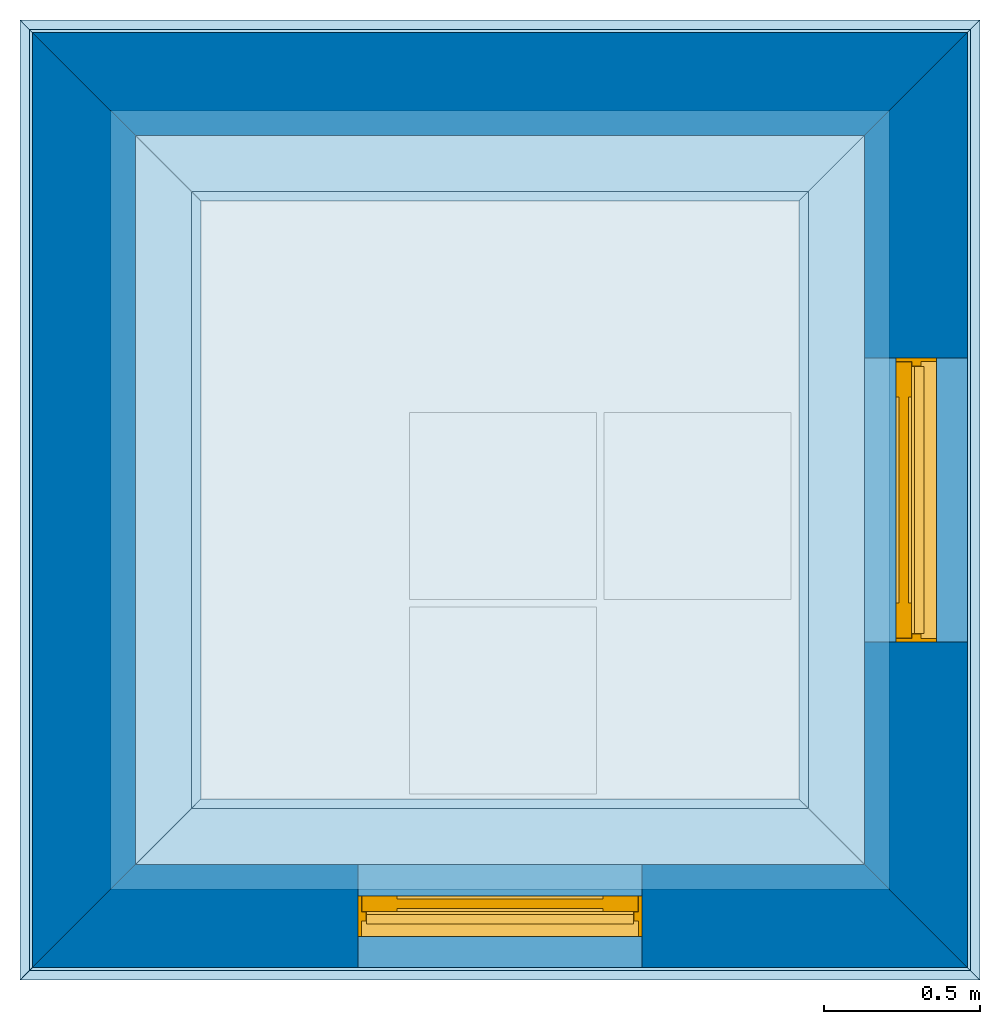
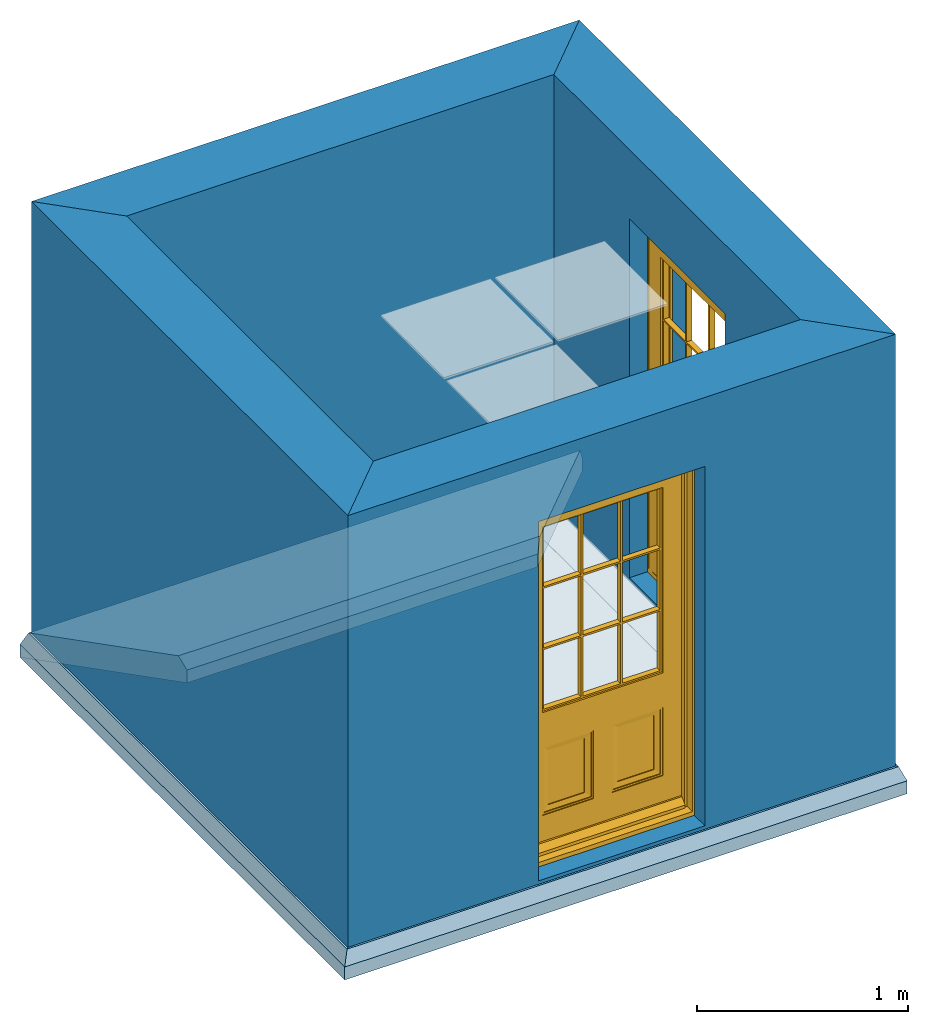
# One storey, part 1 of 3: 4 footings, 4 walls, 2 doors, 1 slab, 2 openings, 3 elements without a shape of their own.
"""IFC4 building model written with IfcOpenShell, lengths in metres."""

import ifcopenshell
import ifcopenshell.guid

model = None  # the IFC model being written
_history = None  # IfcOwnerHistory: only IFC2X3 demands one
_inside = {}  # id of a spatial element -> (the spatial element, [elements in it])
_under = {}  # id of a project, library or spatial element -> (it, [spatial elements below it])
_declared = {}  # id of a project -> (the project, [libraries it declares])
_typed = {}  # id of a type object -> (the type object, [elements of that type])
_made_of = {}  # id of a material, layer set ... -> (it, [elements and type objects made of it])


def new_model(schema):
    """Start an empty IFC model of exactly this schema.

    Asked for "IFC4X3", IfcOpenShell would pick the latest addendum, in which some entities
    have other attributes; the version numbers below select the first issue.
    IFC2X3 requires an IfcOwnerHistory on every rooted entity: one is made here for all.
    """
    global model, _history
    if schema == "IFC4X3":
        model = ifcopenshell.file(schema_version=(4, 3, 0, 0))
    else:
        model = ifcopenshell.file(schema=schema)
    _inside.clear()
    _under.clear()
    _declared.clear()
    _typed.clear()
    _made_of.clear()
    _history = None
    if model.schema == "IFC2X3":
        org = make("IfcOrganization", Name="unknown")
        user = make(
            "IfcPersonAndOrganization",
            ThePerson=make("IfcPerson", FamilyName="unknown"),
            TheOrganization=org,
        )
        app = make(
            "IfcApplication",
            ApplicationDeveloper=org,
            Version="unknown",
            ApplicationFullName="unknown",
            ApplicationIdentifier="unknown",
        )
        _history = make(
            "IfcOwnerHistory",
            OwningUser=user,
            OwningApplication=app,
            ChangeAction="ADDED",
            CreationDate=0,
        )
    return model


def make(cls, **values):
    """One entity of the class cls with the attributes given. An attribute that is None is left unset."""
    return model.create_entity(
        cls, **{name: value for name, value in values.items() if value is not None}
    )


def rooted(cls, **values):
    """An entity with a GlobalId (a new one), such as an element, a storey or a relation."""
    return make(cls, GlobalId=ifcopenshell.guid.new(), OwnerHistory=_history, **values)


def si_unit(unit_type, name, prefix=None):
    """IfcSIUnit, for example si_unit("LENGTHUNIT", "METRE", prefix="MILLI")."""
    return make("IfcSIUnit", UnitType=unit_type, Prefix=prefix, Name=name)


def assignment(units):
    """IfcUnitAssignment: the units of a project."""
    return None if units is None else make("IfcUnitAssignment", Units=units)


def point(xyz):
    """IfcCartesianPoint."""
    return None if xyz is None else make("IfcCartesianPoint", Coordinates=xyz)


def direction(xyz):
    """IfcDirection."""
    return None if xyz is None else make("IfcDirection", DirectionRatios=xyz)


def frame(location, z_axis=None, x_axis=None):
    """IfcAxis2Placement3D, a coordinate frame: its origin and axes. An axis left out is left unset."""
    return make(
        "IfcAxis2Placement3D",
        Location=point(location),
        Axis=direction(z_axis),
        RefDirection=direction(x_axis),
    )


def frame_2d(location, x_axis=None):
    """IfcAxis2Placement2D, a coordinate frame in the plane: its origin and x axis."""
    return make(
        "IfcAxis2Placement2D", Location=point(location), RefDirection=direction(x_axis)
    )


def origin():
    """The frame at (0, 0, 0) with its axes left unset."""
    return frame((0.0, 0.0, 0.0))


def origin_with_axes():
    """The frame at (0, 0, 0) with the z axis (0, 0, 1) and the x axis (1, 0, 0) written out."""
    return frame((0.0, 0.0, 0.0), z_axis=(0.0, 0.0, 1.0), x_axis=(1.0, 0.0, 0.0))


def origin_2d_with_axis():
    """The frame at (0, 0) in the plane with the x axis (1, 0) written out."""
    return frame_2d((0.0, 0.0), x_axis=(1.0, 0.0))


def place(relative_to, where):
    """IfcLocalPlacement: puts the frame where relative to a parent placement (None: the world)."""
    return make(
        "IfcLocalPlacement", PlacementRelTo=relative_to, RelativePlacement=where
    )


def context(
    kind, dimensions, precision=None, world=None, true_north=None, identifier=None
):
    """IfcGeometricRepresentationContext, for example the 3D "Model" context."""
    return make(
        "IfcGeometricRepresentationContext",
        ContextIdentifier=identifier,
        ContextType=kind,
        CoordinateSpaceDimension=dimensions,
        Precision=precision,
        WorldCoordinateSystem=world,
        TrueNorth=true_north,
    )


def subcontext(parent, identifier, kind, view, scale=None):
    """IfcGeometricRepresentationSubContext, for example "Body" below "Model"."""
    return make(
        "IfcGeometricRepresentationSubContext",
        ContextIdentifier=identifier,
        ContextType=kind,
        ParentContext=parent,
        TargetScale=scale,
        TargetView=view,
    )


def project(units=None, contexts=None):
    """IfcProject with its units and contexts."""
    return rooted(
        "IfcProject",
        Name="project",
        RepresentationContexts=contexts,
        UnitsInContext=assignment(units),
    )


def library(units=None, contexts=None, declared=None):
    """IfcProjectLibrary with its units and contexts. declared: the project that declares it."""
    lib = rooted(
        "IfcProjectLibrary",
        RepresentationContexts=contexts,
        UnitsInContext=assignment(units),
    )
    if declared is not None:
        _declared.setdefault(declared.id(), (declared, []))[1].append(lib)
    return lib


def spatial(cls, under=None, at=None, **own):
    """A site, building, storey or space (cls), placed at a placement, below another one or the project."""
    s = rooted(cls, ObjectPlacement=at, **own)
    if under is not None:
        _under.setdefault(under.id(), (under, []))[1].append(s)
    return s


def polyline(points):
    """IfcPolyline through the points."""
    return make("IfcPolyline", Points=[point(p) for p in points])


def point_list(points):
    """IfcCartesianPointList2D or 3D."""
    cls = (
        "IfcCartesianPointList2D" if len(points[0]) == 2 else "IfcCartesianPointList3D"
    )
    return make(cls, CoordList=points)


def outline(outer, holes=None, kind="AREA"):
    """IfcArbitraryClosedProfileDef: a profile drawn as a closed curve; with holes, ...WithVoids."""
    if holes is None:
        return make("IfcArbitraryClosedProfileDef", ProfileType=kind, OuterCurve=outer)
    return make(
        "IfcArbitraryProfileDefWithVoids",
        ProfileType=kind,
        OuterCurve=outer,
        InnerCurves=holes,
    )


def extrude(swept, where, along, depth):
    """IfcExtrudedAreaSolid: the profile swept, set in the frame where, extruded along a direction by depth."""
    return make(
        "IfcExtrudedAreaSolid",
        SweptArea=swept,
        Position=where,
        ExtrudedDirection=direction(along),
        Depth=depth,
    )


def clip(a, b, op="DIFFERENCE"):
    """IfcBooleanClippingResult: the solid a cut by the half space b."""
    return make(
        "IfcBooleanClippingResult", Operator=op, FirstOperand=a, SecondOperand=b
    )


def halfspace(plane, agree):
    """IfcHalfSpaceSolid: all space on one side of the plane z = 0 of the frame plane."""
    return make(
        "IfcHalfSpaceSolid",
        BaseSurface=make("IfcPlane", Position=plane),
        AgreementFlag=agree,
    )


def polygons(points, faces, closed=None, point_numbers=None):
    """IfcPolygonalFaceSet: a face is its outer loop, then its inner loops; points numbered from 1."""
    made = []
    for loops in faces:
        if len(loops) == 1:
            made.append(make("IfcIndexedPolygonalFace", CoordIndex=loops[0]))
        else:
            made.append(
                make(
                    "IfcIndexedPolygonalFaceWithVoids",
                    CoordIndex=loops[0],
                    InnerCoordIndices=loops[1:],
                )
            )
    return make(
        "IfcPolygonalFaceSet",
        Coordinates=point_list(points),
        Closed=closed,
        Faces=made,
        PnIndex=point_numbers,
    )


def shape(context_of_items, identifier, shape_type, items):
    """IfcShapeRepresentation: the items that make up one representation, for example the "Body"."""
    return make(
        "IfcShapeRepresentation",
        ContextOfItems=context_of_items,
        RepresentationIdentifier=identifier,
        RepresentationType=shape_type,
        Items=items,
    )


def source(mapping_origin, context_of_items, identifier, shape_type, items):
    """IfcRepresentationMap: a shape defined once, which mapped items show again and again."""
    return make(
        "IfcRepresentationMap",
        MappingOrigin=mapping_origin,
        MappedRepresentation=shape(context_of_items, identifier, shape_type, items),
    )


def transform(
    local_origin,
    x_axis=None,
    y_axis=None,
    z_axis=None,
    scale=None,
    scale2=None,
    scale3=None,
    uniform=True,
):
    """IfcCartesianTransformationOperator3D, or its non-uniform kind. x_axis, y_axis, z_axis: its Axis1, 2, 3."""
    if uniform:
        return make(
            "IfcCartesianTransformationOperator3D",
            Axis1=direction(x_axis),
            Axis2=direction(y_axis),
            LocalOrigin=point(local_origin),
            Scale=scale,
            Axis3=direction(z_axis),
        )
    return make(
        "IfcCartesianTransformationOperator3DnonUniform",
        Axis1=direction(x_axis),
        Axis2=direction(y_axis),
        LocalOrigin=point(local_origin),
        Scale=scale,
        Axis3=direction(z_axis),
        Scale2=scale2,
        Scale3=scale3,
    )


def mapped(mapping_source, mapping_target):
    """IfcMappedItem: shows the shape of a source again, moved by a transform."""
    return make(
        "IfcMappedItem", MappingSource=mapping_source, MappingTarget=mapping_target
    )


def material(Name=None, Category=None):
    """IfcMaterial."""
    return make("IfcMaterial", Name=Name, Category=Category)


def layer(
    of_material, thickness, ventilated=None, Name=None, Category=None, Priority=None
):
    """IfcMaterialLayer: one layer of a wall or slab, of a material (None: an air gap)."""
    return make(
        "IfcMaterialLayer",
        Material=of_material,
        LayerThickness=thickness,
        IsVentilated=ventilated,
        Name=Name,
        Category=Category,
        Priority=Priority,
    )


def layer_set(layers, Name=None):
    """IfcMaterialLayerSet."""
    return make("IfcMaterialLayerSet", MaterialLayers=layers, LayerSetName=Name)


def layer_usage(for_layer_set, set_direction, sense, offset, extent=None):
    """IfcMaterialLayerSetUsage: how a layer set lies in its element."""
    return make(
        "IfcMaterialLayerSetUsage",
        ForLayerSet=for_layer_set,
        LayerSetDirection=set_direction,
        DirectionSense=sense,
        OffsetFromReferenceLine=offset,
        ReferenceExtent=extent,
    )


def material_profile(
    of_material, cross_section, Name=None, Category=None, Priority=None
):
    """IfcMaterialProfile: a cross section and its material."""
    return make(
        "IfcMaterialProfile",
        Name=Name,
        Material=of_material,
        Profile=cross_section,
        Priority=Priority,
        Category=Category,
    )


def profile_set(profiles, Name=None, composite=None):
    """IfcMaterialProfileSet."""
    return make(
        "IfcMaterialProfileSet",
        Name=Name,
        MaterialProfiles=profiles,
        CompositeProfile=composite,
    )


def profile_usage(for_profile_set, cardinal=None, extent=None):
    """IfcMaterialProfileSetUsage: how a profile set lies along its element."""
    return make(
        "IfcMaterialProfileSetUsage",
        ForProfileSet=for_profile_set,
        CardinalPoint=cardinal,
        ReferenceExtent=extent,
    )


def made_of(thing, what):
    """Note that an element or type object is made of a material, layer set ...; save() writes the relation."""
    if what is not None:
        _made_of.setdefault(what.id(), (what, []))[1].append(thing)
    return thing


def type_object(cls, material=None, **own):
    """A type object (cls), such as IfcWallType, which elements share."""
    return made_of(rooted(cls, **own), material)


def type_shapes(of_type, sources):
    """Give a type object the sources (RepresentationMaps) that its elements show as mapped items."""
    of_type.RepresentationMaps = sources


def element(
    cls,
    number,
    at=None,
    inside=None,
    cuts=None,
    type_object=None,
    material=None,
    context=None,
    identifier="Body",
    shape_type=None,
    held_by="IfcProductDefinitionShape",
    body=None,
    shapes=None,
    **own,
):
    """One element of the class cls, such as IfcWall. Its Tag is "e" and its number.

    at: its placement. inside: the storey or other place that contains it. cuts: it is an
    opening in that element (IfcRelVoidsElement). A single representation is given by context,
    identifier, shape_type and body (its items); several are given by shapes. held_by: the class
    of the entity that holds the representations. save() writes the other relations.
    """
    e = rooted(cls, Tag="e%d" % number, ObjectPlacement=at, **own)
    if body is not None:
        shapes = [shape(context, identifier, shape_type, body)]
    if shapes is not None:
        e.Representation = make(held_by, Representations=shapes)
    if inside is not None:
        _inside.setdefault(inside.id(), (inside, []))[1].append(e)
    if cuts is not None:
        rooted(
            "IfcRelVoidsElement", RelatingBuildingElement=cuts, RelatedOpeningElement=e
        )
    if type_object is not None:
        _typed.setdefault(type_object.id(), (type_object, []))[1].append(e)
    return made_of(e, material)


def fill(opening, filler):
    """IfcRelFillsElement: the door or window that sits in an opening."""
    return rooted(
        "IfcRelFillsElement",
        RelatingOpeningElement=opening,
        RelatedBuildingElement=filler,
    )


def aggregate(whole, parts):
    """IfcRelAggregates: a whole, such as a stair, and the parts it consists of."""
    return rooted("IfcRelAggregates", RelatingObject=whole, RelatedObjects=parts)


def save(model, path):
    """Write the relations noted so far, then the file.

    IfcRelAggregates (storeys below a building ...), IfcRelContainedInSpatialStructure (elements
    in a storey), IfcRelDefinesByType, IfcRelAssociatesMaterial and IfcRelDeclares: one each for
    every whole, place, type object, material and project.
    """
    for whole, parts in _under.values():
        aggregate(whole, parts)
    for where, things in _inside.values():
        rooted(
            "IfcRelContainedInSpatialStructure",
            RelatedElements=things,
            RelatingStructure=where,
        )
    for kind, things in _typed.values():
        rooted("IfcRelDefinesByType", RelatedObjects=things, RelatingType=kind)
    for what, things in _made_of.values():
        rooted("IfcRelAssociatesMaterial", RelatedObjects=things, RelatingMaterial=what)
    for by, libraries in _declared.values():
        rooted("IfcRelDeclares", RelatingContext=by, RelatedDefinitions=libraries)
    model.write(path)


model = new_model("IFC4")

# Units and contexts
model_context = context("Model", 3, precision=1e-05, world=origin_with_axes())
plan_context = context("Plan", 2, precision=1e-05, world=origin_2d_with_axis())
body_context = subcontext(model_context, "Body", "Model", "MODEL_VIEW")
ifc_project = project(units=[si_unit("LENGTHUNIT", "METRE"), si_unit("AREAUNIT", "SQUARE_METRE"), si_unit("VOLUMEUNIT", "CUBIC_METRE"), si_unit("PLANEANGLEUNIT", "RADIAN")], contexts=[model_context, plan_context])
project_library = library(declared=ifc_project)

# Site, building, storey
site = spatial("IfcSite", under=ifc_project)
building = spatial("IfcBuilding", under=site, Name="Cube")
storey_placement = place(None, origin_with_axes())
storey = spatial("IfcBuildingStorey", under=building, at=storey_placement, Name="0", CompositionType="ELEMENT", Elevation=0.0)

# Assembly, footings
assembly_1_placement = place(storey_placement, origin_with_axes())
assembly_1 = element("IfcElementAssembly", 1, at=assembly_1_placement, inside=storey, Name="ground beam")
ifc_material_1 = material(Name="Concrete", Category="concrete")
ifc_material_profile = material_profile(ifc_material_1, outline(polyline([(-0.26, 0.0), (-0.29, -0.075), (-0.29, -0.15), (0.29, -0.15), (0.29, -0.075), (0.26, 0.0), (-0.26, 0.0)])))
ifc_profile_set = profile_set([ifc_material_profile])
ifc_profile_usage_1 = profile_usage(ifc_profile_set)
footing_type = type_object("IfcFootingType", Name="ground beam", PredefinedType="NOTDEFINED", material=ifc_profile_set)
footing_1_placement = place(assembly_1_placement, frame((-1.0, 2.5, 0.0), z_axis=(1.0, 0.0, 0.0), x_axis=(0.0, 1.0, 0.0)))
footing_1 = element("IfcFooting", 2, at=footing_1_placement, type_object=footing_type, material=ifc_profile_usage_1, Name="ground beam", context=body_context, shape_type="Clipping", body=[
    clip(clip(extrude(outline(polyline([(-0.26, 0.0), (-0.29, -0.075), (-0.29, -0.15), (0.29, -0.15), (0.29, -0.075), (0.26, 0.0), (-0.26, 0.0)])), origin_with_axes(), (0.0, 0.0, 1.0), 4.5), halfspace(frame((0.0, 0.0, 1.0), z_axis=(-0.707106781186547, 0.0, -0.707106781186547), x_axis=(0.707106781186547, 0.0, -0.707106781186547)), False)), halfspace(frame((0.0, 0.0, 3.5), z_axis=(-0.707106781186547, 0.0, 0.707106781186547), x_axis=(0.707106781186547, 0.0, 0.707106781186547)), False)),
])
ifc_profile_usage_2 = profile_usage(ifc_profile_set)
footing_2_placement = place(assembly_1_placement, frame((0.0, -1.0, 0.0), z_axis=(0.0, 1.0, 0.0), x_axis=(-1.0, 0.0, 0.0)))
footing_2 = element("IfcFooting", 3, at=footing_2_placement, type_object=footing_type, material=ifc_profile_usage_2, Name="ground beam", context=body_context, shape_type="Clipping", body=[
    clip(clip(extrude(outline(polyline([(-0.26, 0.0), (-0.29, -0.075), (-0.29, -0.15), (0.29, -0.15), (0.29, -0.075), (0.26, 0.0), (-0.26, 0.0)])), origin_with_axes(), (0.0, 0.0, 1.0), 4.5), halfspace(frame((0.0, 0.0, 1.0), z_axis=(-0.707106781186547, 0.0, -0.707106781186547), x_axis=(0.707106781186547, 0.0, -0.707106781186547)), False)), halfspace(frame((0.0, 0.0, 3.5), z_axis=(-0.707106781186547, 0.0, 0.707106781186547), x_axis=(0.707106781186547, 0.0, 0.707106781186547)), False)),
])
ifc_profile_usage_3 = profile_usage(ifc_profile_set)
footing_3_placement = place(assembly_1_placement, frame((3.5, 0.0, 0.0), z_axis=(-1.0, 0.0, 0.0), x_axis=(0.0, -1.0, 0.0)))
footing_3 = element("IfcFooting", 4, at=footing_3_placement, type_object=footing_type, material=ifc_profile_usage_3, Name="ground beam", context=body_context, shape_type="Clipping", body=[
    clip(clip(extrude(outline(polyline([(-0.26, 0.0), (-0.29, -0.075), (-0.29, -0.15), (0.29, -0.15), (0.29, -0.075), (0.26, 0.0), (-0.26, 0.0)])), origin_with_axes(), (0.0, 0.0, 1.0), 4.5), halfspace(frame((0.0, 0.0, 1.0), z_axis=(-0.707106781186547, 0.0, -0.707106781186547), x_axis=(0.707106781186547, 0.0, -0.707106781186547)), False)), halfspace(frame((0.0, 0.0, 3.5), z_axis=(-0.707106781186547, 0.0, 0.707106781186547), x_axis=(0.707106781186547, 0.0, 0.707106781186547)), False)),
])
ifc_profile_usage_4 = profile_usage(ifc_profile_set)
footing_4_placement = place(assembly_1_placement, frame((2.5, 3.5, 0.0), z_axis=(0.0, -1.0, 0.0), x_axis=(1.0, 0.0, 0.0)))
footing_4 = element("IfcFooting", 5, at=footing_4_placement, type_object=footing_type, material=ifc_profile_usage_4, Name="ground beam", context=body_context, shape_type="Clipping", body=[
    clip(clip(extrude(outline(polyline([(-0.26, 0.0), (-0.29, -0.075), (-0.29, -0.15), (0.29, -0.15), (0.29, -0.075), (0.26, 0.0), (-0.26, 0.0)])), origin_with_axes(), (0.0, 0.0, 1.0), 4.5), halfspace(frame((0.0, 0.0, 1.0), z_axis=(-0.707106781186547, 0.0, -0.707106781186547), x_axis=(0.707106781186547, 0.0, -0.707106781186547)), False)), halfspace(frame((0.0, 0.0, 3.5), z_axis=(-0.707106781186547, 0.0, 0.707106781186547), x_axis=(0.707106781186547, 0.0, 0.707106781186547)), False)),
])
aggregate(assembly_1, [footing_1, footing_2, footing_3, footing_4])

# Assembly, slab
assembly_2_placement = place(storey_placement, origin_with_axes())
assembly_2 = element("IfcElementAssembly", 6, at=assembly_2_placement, inside=storey, Name="circulation-floor")
ifc_layer_1 = layer(ifc_material_1, 0.18, Name="Concrete")
ifc_material_2 = material(Name="Screed")
ifc_layer_2 = layer(ifc_material_2, 0.02, Name="Screed")
ifc_layer_set_1 = layer_set([ifc_layer_1, ifc_layer_2], Name="default/circulation-floor")
ifc_layer_usage_1 = layer_usage(ifc_layer_set_1, "AXIS3", "POSITIVE", 0.0)
slab_type = type_object("IfcSlabType", Name="circulation-floor", PredefinedType="FLOOR", material=ifc_layer_set_1)
slab_placement = place(assembly_2_placement, frame((0.0, 2.5, -0.2), z_axis=(0.0, 0.0, -1.0), x_axis=(0.0, 1.0, 0.0)))
slab = element("IfcSlab", 7, at=slab_placement, type_object=slab_type, material=ifc_layer_usage_1, Name="circulation-floor", context=body_context, shape_type="SweptSolid", body=[
    extrude(outline(polyline([(0.0, 0.0), (0.0, 2.5), (-2.5, 2.5), (-2.5, 0.0), (0.0, 0.0)])), origin(), (0.0, 0.0, -1.0), 0.2),
])
aggregate(assembly_2, [slab])

# Assembly, walls, opening
assembly_3_placement = place(storey_placement, frame((2.5, 2.5, 0.0), z_axis=(0.0, 0.0, 1.0), x_axis=(-1.0, 0.0, 0.0)))
assembly_3 = element("IfcElementAssembly", 8, at=assembly_3_placement, inside=storey, Name="exterior")
ifc_material_3 = material(Name="Masonry")
ifc_layer_3 = layer(ifc_material_3, 0.3, Name="Masonry")
ifc_material_4 = material(Name="Plaster")
ifc_layer_4 = layer(ifc_material_4, 0.03, Name="Plaster")
ifc_layer_set_2 = layer_set([ifc_layer_3, ifc_layer_4], Name="default/exterior")
ifc_layer_usage_2 = layer_usage(ifc_layer_set_2, "AXIS2", "POSITIVE", -0.25)
wall_type = type_object("IfcWallType", Name="exterior", PredefinedType="SOLIDWALL", material=ifc_layer_set_2)
wall_1_placement = place(assembly_3_placement, origin_with_axes())
wall_1 = element("IfcWall", 9, at=wall_1_placement, type_object=wall_type, material=ifc_layer_usage_2, Name="exterior", context=body_context, shape_type="SweptSolid", body=[
    extrude(outline(polyline([(0.0799999999903198, 0.0799560546875), (-0.250000000011, -0.25), (2.750000000001, -0.25), (2.41999999999968, 0.0800000000000001), (0.0799999999903198, 0.0799560546875)])), origin(), (0.0, 0.0, 1.0), 2.5),
])
ifc_layer_usage_3 = layer_usage(ifc_layer_set_2, "AXIS2", "POSITIVE", -0.25)
wall_2_placement = place(assembly_3_placement, frame((2.5, 0.0, 0.0), z_axis=(0.0, 0.0, 1.0), x_axis=(0.0, 1.0, 0.0)))
wall_2 = element("IfcWall", 10, at=wall_2_placement, type_object=wall_type, material=ifc_layer_usage_3, Name="exterior", context=body_context, shape_type="SweptSolid", body=[
    extrude(outline(polyline([(0.0800000000000001, 0.08000000000032), (-0.25, -0.250000000001), (2.75, -0.249999999989), (2.41999816894531, 0.08000000000968), (0.0800000000000001, 0.08000000000032)])), origin(), (0.0, 0.0, 1.0), 2.5),
])
ifc_layer_usage_4 = layer_usage(ifc_layer_set_2, "AXIS2", "POSITIVE", -0.25)
wall_3_placement = place(assembly_3_placement, frame((2.5, 2.5, 0.0), z_axis=(0.0, 0.0, 1.0), x_axis=(-1.0, 0.0, 0.0)))
wall_3 = element("IfcWall", 11, at=wall_3_placement, type_object=wall_type, material=ifc_layer_usage_4, Name="exterior", context=body_context, shape_type="SweptSolid", body=[
    extrude(outline(polyline([(0.08000000000968, 0.0800018310546875), (-0.249999999989, -0.25), (2.749999999999, -0.25), (2.42000000000032, 0.08), (0.08000000000968, 0.0800018310546875)])), origin(), (0.0, 0.0, 1.0), 2.5),
])
opening_1_placement = place(wall_3_placement, frame((0.795, -0.25, 0.02), z_axis=(0.0, 0.0, 1.0), x_axis=(1.0, 0.0, 0.0)))
opening_1 = element("IfcOpeningElement", 12, at=opening_1_placement, cuts=wall_3, Name="door", PredefinedType="OPENING", context=body_context, shape_type="SweptSolid", body=[
    extrude(outline(polyline([(0.0, -0.02), (0.91, -0.02), (0.91, 0.35), (0.0, 0.35), (0.0, -0.02)])), origin(), (0.0, 0.0, 1.0), 2.08),
])

# Space
space_placement = place(storey_placement, frame((0.0, 0.0, 0.02), z_axis=(0.0, 0.0, 1.0), x_axis=(1.0, 0.0, 0.0)))
space = spatial("IfcSpace", under=storey, at=space_placement, PredefinedType="INTERNAL")

# Door
ifc_material_5 = material(Name="Timber")
door_type = type_object("IfcDoorType", Name="door", OperationType="SINGLE_SWING_LEFT", PredefinedType="DOOR", material=ifc_material_5)
shared_shape = source(origin_with_axes(), body_context, "Body", "Tessellation", [
    polygons([(0.545, 0.195, 0.265), (0.745, 0.195, 0.265), (0.745, 0.2, 0.265), (0.545, 0.2, 0.265), (0.545, 0.195, 0.58), (0.775, 0.19, 0.235), (0.745, 0.2, 0.58), (0.545, 0.2, 0.58), (0.515, 0.19, 0.235), (0.775, 0.19, 0.61), (0.745, 0.195, 0.58), (0.515, 0.185, 0.235), (0.775, 0.185, 0.235), (0.775, 0.185, 0.61), (0.515, 0.19, 0.61), (0.515, 0.185, 0.61), (0.785, 0.185, 0.62), (0.785, 0.185, 0.225), (0.505, 0.185, 0.225), (0.785, 0.18, 0.225), (0.505, 0.18, 0.225), (0.785, 0.18, 0.62), (0.505, 0.185, 0.62), (0.505, 0.18, 0.62), (0.027, 0.18, 0.075), (0.785, 0.18, 0.82), (0.405, 0.18, 0.225), (0.405, 0.18, 0.62), (0.883, 0.18, 0.075), (0.012, 0.18, 0.075), (0.125, 0.19, 0.82), (0.125, 0.18, 0.62), (0.395, 0.185, 0.61), (0.405, 0.185, 0.225), (0.405, 0.185, 0.62), (0.125, 0.185, 0.225), (0.883, 0.14, 0.045), (0.883, 0.17, 0.075), (0.785, 0.19, 0.82), (0.125, 0.18, 0.82), (0.125, 0.19, 1.895), (0.785, 0.18, 1.895), (0.125, 0.185, 0.62), (0.125, 0.18, 0.225), (0.395, 0.185, 0.235), (0.395, 0.19, 0.61), (0.125, 0.18, 1.895), (0.351667046546936, 0.19, 0.83), (0.351667046546936, 0.22, 0.83), (0.341667085886002, 0.19, 0.83), (0.785, 0.19, 1.895), (0.135, 0.19, 0.61), (0.395, 0.19, 0.235), (0.365, 0.195, 0.58), (0.775, 0.19, 0.83), (0.558332860469818, 0.19, 0.83), (0.558332860469818, 0.22, 0.83), (0.351667046546936, 0.19, 1.175), (0.341667085886002, 0.19, 1.175), (0.135, 0.19, 1.175), (0.135, 0.19, 1.53), (0.135, 0.19, 1.185), (0.135, 0.19, 1.54), (0.351667046546936, 0.19, 1.885), (0.558332860469818, 0.19, 1.885), (0.775, 0.22, 1.53), (0.775, 0.19, 1.53), (0.775, 0.19, 1.175), (0.775, 0.19, 1.54), (0.135, 0.185, 0.61), (0.135, 0.185, 0.235), (0.365, 0.195, 0.265), (0.568332850933075, 0.22, 0.83), (0.568332850933075, 0.19, 0.83), (0.558332860469818, 0.19, 1.185), (0.558332860469818, 0.19, 1.175), (0.558332860469818, 0.22, 1.175), (0.785, 0.23, 0.82), (0.125, 0.22, 0.82), (0.341667085886002, 0.22, 0.83), (0.341667085886002, 0.22, 1.175), (0.351667046546936, 0.22, 1.175), (0.135, 0.19, 0.83), (0.341667085886002, 0.19, 1.185), (0.341667085886002, 0.22, 1.185), (0.135, 0.22, 1.185), (0.125, 0.22, 1.895), (0.135, 0.22, 1.53), (0.341667085886002, 0.19, 1.54), (0.341667085886002, 0.19, 1.53), (0.341667085886002, 0.19, 1.885), (0.558332860469818, 0.22, 1.885), (0.568332850933075, 0.19, 1.885), (0.775, 0.19, 1.185), (0.775, 0.22, 1.185), (0.568332850933075, 0.19, 1.54), (0.568332850933075, 0.19, 1.53), (0.165, 0.195, 0.58), (0.135, 0.19, 0.235), (0.165, 0.2, 0.58), (0.365, 0.2, 0.265), (0.365, 0.2, 0.58), (0.165, 0.2, 0.265), (0.165, 0.195, 0.265), (0.568332850933075, 0.19, 1.175), (0.568332850933075, 0.22, 1.175), (0.775, 0.22, 1.175), (0.775, 0.22, 0.83), (0.558332860469818, 0.22, 1.185), (0.125, 0.23, 0.82), (0.785, 0.22, 0.82), (0.135, 0.22, 0.83), (0.135, 0.22, 1.175), (0.135, 0.22, 1.54), (0.341667085886002, 0.22, 1.53), (0.341667085886002, 0.22, 1.54), (0.351667046546936, 0.22, 1.885), (0.568332850933075, 0.19, 1.185), (0.568332850933075, 0.22, 1.185), (0.568332850933075, 0.22, 1.54), (0.568332850933075, 0.22, 1.53), (0.775, 0.22, 1.54), (0.558332860469818, 0.19, 1.53), (0.351667046546936, 0.19, 1.185), (0.785, 0.23, 0.62), (0.785, 0.22, 1.895), (0.125, 0.23, 1.895), (0.785, 0.23, 1.895), (0.351667046546936, 0.19, 1.53), (0.351667046546936, 0.22, 1.185), (0.351667046546936, 0.22, 1.53), (0.135, 0.19, 1.885), (0.135, 0.22, 1.885), (0.341667085886002, 0.22, 1.885), (0.558332860469818, 0.19, 1.54), (0.558332860469818, 0.22, 1.54), (0.351667046546936, 0.22, 1.54), (0.351667046546936, 0.19, 1.54), (0.775, 0.22, 1.885), (0.775, 0.19, 1.885), (0.568332850933075, 0.22, 1.885), (0.558332860469818, 0.22, 1.53), (0.405, 0.225, 0.225), (0.405, 0.225, 0.62), (0.505, 0.23, 0.62), (0.405, 0.23, 0.225), (0.405, 0.23, 0.62), (0.125, 0.23, 0.62), (0.505, 0.225, 0.225), (0.505, 0.225, 0.62), (0.785, 0.23, 0.225), (0.505, 0.23, 0.225), (0.135, 0.225, 0.61), (0.125, 0.225, 0.62), (0.125, 0.23, 0.225), (0.125, 0.225, 0.225), (0.775, 0.225, 0.61), (0.785, 0.225, 0.62), (0.515, 0.225, 0.235), (0.515, 0.225, 0.61), (0.515, 0.22, 0.61), (0.785, 0.225, 0.225), (0.395, 0.225, 0.61), (0.775, 0.22, 0.61), (0.395, 0.225, 0.235), (0.395, 0.22, 0.61), (0.395, 0.22, 0.235), (0.515, 0.22, 0.235), (0.135, 0.225, 0.235), (0.365, 0.215, 0.58), (0.135, 0.22, 0.61), (0.775, 0.22, 0.235), (0.775, 0.225, 0.235), (0.745, 0.215, 0.58), (0.135, 0.22, 0.235), (0.365, 0.215, 0.265), (0.365, 0.21, 0.58), (0.545, 0.215, 0.58), (0.545, 0.215, 0.265), (0.165, 0.215, 0.58), (0.745, 0.21, 0.58), (0.545, 0.21, 0.58), (0.165, 0.215, 0.265), (0.165, 0.21, 0.58), (0.365, 0.21, 0.265), (0.745, 0.21, 0.265), (0.545, 0.21, 0.265), (0.165, 0.21, 0.265), (0.745, 0.215, 0.265), (0.025, 0.178, 0.025), (0.01, 0.23, 0.025), (0.9, 0.178, 0.025), (0.9, 0.23, 0.025), (0.025, 0.178, 2.055), (0.01, 0.23, 2.07), (0.01, 0.178, 0.025), (0.01, 0.178, 2.07), (0.9, 0.23, 2.07), (0.9, 0.178, 2.07), (0.91, 0.23, 2.08), (0.0, 0.23, 2.08), (0.0, 0.1, 2.08), (0.01, 0.1, 2.07), (0.01, 0.15, 2.07), (0.9, 0.15, 2.07), (0.0, 0.23, 0.0), (0.0, 0.1, 0.0), (0.91, 0.23, 0.0), (0.91, 0.1, 0.0), (0.91, 0.1, 2.08), (0.01, 0.1, 0.025), (0.9, 0.1, 2.07), (0.9, 0.1, 0.025), (0.025, 0.15, 0.025), (0.025, 0.15, 2.055), (0.01, 0.15, 0.025), (0.9, 0.15, 0.025), (0.885, 0.15, 0.025), (0.885, 0.178, 2.055), (0.885, 0.178, 0.025), (0.885, 0.15, 2.055), (0.898, 0.18, 2.068), (0.012, 0.23, 2.068), (0.898, 0.23, 0.027), (0.898, 0.23, 2.068), (0.012, 0.18, 2.068), (0.012, 0.18, 0.027), (0.898, 0.18, 0.027), (0.898, 0.18, 0.075), (0.012, 0.23, 0.027), (0.027, 0.17, 0.075), (0.027, 0.14, 0.027), (0.027, 0.18, 0.027), (0.883, 0.18, 0.027), (0.883, 0.14, 0.027), (0.027, 0.14, 0.045)], [[[1, 2, 3, 4]], [[3, 7, 8, 4]], [[1, 4, 8, 5]], [[2, 1, 9, 6]], [[11, 7, 3, 2]], [[11, 5, 8, 7]], [[1, 5, 15, 9]], [[6, 9, 12, 13]], [[6, 10, 11, 2]], [[10, 15, 5, 11]], [[9, 15, 16, 12]], [[18, 13, 12, 19]], [[13, 14, 10, 6]], [[14, 16, 15, 10]], [[23, 19, 12, 16]], [[18, 17, 14, 13]], [[18, 19, 21, 20]], [[16, 14, 17, 23]], [[19, 23, 24, 21]], [[20, 22, 17, 18]], [[29, 229, 20, 21]], [[22, 24, 23, 17]], [[21, 24, 28, 27]], [[22, 20, 229]], [[25, 29, 21, 27]], [[24, 22, 26]], [[26, 40, 28, 24]], [[27, 28, 35, 34]], [[22, 229, 222, 26]], [[231, 38, 29, 25]], [[25, 27, 44, 30]], [[39, 31, 40, 26]], [[28, 40, 32]], [[28, 32, 43, 35]], [[33, 45, 34, 35]], [[34, 36, 44, 27]], [[222, 42, 26]], [[236, 37, 38, 231]], [[44, 32, 30]], [[31, 39, 56, 48]], [[47, 40, 31, 41]], [[26, 42, 51, 39]], [[226, 30, 32, 40]], [[36, 43, 32, 44]], [[35, 43, 70, 33]], [[45, 33, 46, 53]], [[71, 36, 34, 45]], [[47, 42, 222, 226]], [[37, 236, 232, 235]], [[74, 56, 39]], [[48, 56, 57, 49]], [[48, 50, 31]], [[47, 226, 40]], [[41, 31, 62, 61]], [[42, 47, 41, 51]], [[67, 94, 39, 51]], [[71, 70, 43, 36]], [[33, 70, 52, 46]], [[53, 46, 54, 72]], [[53, 99, 71, 45]], [[74, 105, 76, 56]], [[74, 39, 55]], [[56, 76, 77, 57]], [[111, 79, 49, 57]], [[49, 82, 58, 48]], [[48, 58, 59, 50]], [[50, 83, 31]], [[60, 62, 31]], [[61, 62, 86, 88]], [[63, 41, 61]], [[51, 41, 64, 65]], [[66, 95, 94, 67]], [[68, 39, 94]], [[69, 67, 51]], [[99, 52, 70, 71]], [[46, 52, 98, 54]], [[54, 102, 101, 72]], [[72, 104, 99, 53]], [[73, 106, 105, 74]], [[76, 105, 118, 75]], [[55, 39, 68]], [[108, 73, 74, 55]], [[77, 76, 58, 82]], [[57, 77, 106, 73]], [[78, 110, 79, 111]], [[79, 80, 49]], [[73, 111, 57]], [[80, 81, 82, 49]], [[59, 58, 124, 84]], [[50, 59, 81, 80]], [[83, 50, 80, 112]], [[83, 60, 31]], [[84, 62, 60, 59]], [[84, 85, 86, 62]], [[88, 86, 79, 87]], [[115, 90, 61, 88]], [[132, 41, 63]], [[89, 63, 61, 90]], [[91, 64, 41]], [[92, 65, 64, 117]], [[93, 51, 65]], [[126, 111, 95, 66]], [[119, 118, 94, 95]], [[97, 121, 66, 67]], [[94, 118, 105, 68]], [[69, 96, 97, 67]], [[69, 51, 140]], [[104, 98, 52, 99]], [[54, 98, 100, 102]], [[101, 102, 100, 103]], [[101, 103, 104, 72]], [[105, 106, 107, 68]], [[123, 75, 118, 97]], [[75, 124, 58, 76]], [[55, 68, 107, 108]], [[73, 108, 111]], [[130, 109, 77, 82]], [[106, 77, 109, 119]], [[145, 147, 110, 78]], [[87, 79, 110, 127]], [[128, 78, 111, 126]], [[79, 112, 80]], [[82, 81, 85, 130]], [[90, 84, 124, 129]], [[81, 59, 60, 113]], [[112, 113, 60, 83]], [[115, 85, 84, 90]], [[81, 113, 86, 85]], [[86, 113, 79]], [[114, 88, 87]], [[115, 88, 114, 116]], [[91, 41, 132]], [[63, 114, 133, 132]], [[89, 116, 114, 63]], [[90, 129, 138, 89]], [[64, 91, 89, 138]], [[136, 135, 65, 92]], [[138, 137, 117, 64]], [[87, 126, 92, 117]], [[93, 140, 51]], [[93, 65, 135, 96]], [[107, 95, 111]], [[122, 126, 66]], [[97, 118, 119, 121]], [[119, 95, 107, 106]], [[120, 122, 66, 121]], [[120, 96, 69, 122]], [[123, 97, 96, 135]], [[122, 69, 140, 139]], [[100, 98, 104, 103]], [[142, 109, 75, 123]], [[75, 109, 130, 124]], [[108, 107, 111]], [[121, 119, 109, 142]], [[146, 147, 145, 152]], [[147, 148, 110]], [[145, 78, 125]], [[110, 223, 127]], [[126, 87, 127, 128]], [[78, 128, 225]], [[112, 79, 113]], [[131, 130, 85, 115]], [[129, 124, 130, 131]], [[87, 133, 114]], [[131, 115, 116, 137]], [[134, 91, 132, 133]], [[116, 89, 91, 134]], [[135, 138, 129, 123]], [[135, 136, 137, 138]], [[120, 136, 92, 141]], [[137, 116, 134, 117]], [[141, 92, 126]], [[117, 134, 87]], [[93, 141, 139, 140]], [[96, 120, 141, 93]], [[122, 139, 126]], [[121, 142, 136, 120]], [[142, 123, 129, 131]], [[143, 144, 147, 146]], [[152, 145, 150, 149]], [[152, 224, 230, 146]], [[144, 154, 148, 147]], [[230, 223, 110, 148]], [[78, 225, 224, 125]], [[158, 150, 145, 125]], [[223, 225, 128, 127]], [[134, 133, 87]], [[137, 136, 142, 131]], [[139, 141, 126]], [[144, 143, 165, 163]], [[146, 155, 156, 143]], [[160, 159, 149, 150]], [[151, 152, 149, 162]], [[152, 151, 224]], [[155, 146, 230]], [[153, 154, 144, 163]], [[155, 148, 154, 156]], [[155, 230, 148]], [[125, 224, 151]], [[158, 157, 160, 150]], [[162, 158, 125, 151]], [[169, 165, 143, 156]], [[167, 166, 163, 165]], [[159, 160, 161, 168]], [[162, 149, 159, 173]], [[156, 154, 153, 169]], [[166, 171, 153, 163]], [[173, 157, 158, 162]], [[164, 161, 160, 157]], [[165, 169, 175, 167]], [[176, 170, 166, 167]], [[168, 161, 178, 179]], [[173, 159, 168, 172]], [[169, 153, 171, 175]], [[170, 180, 171, 166]], [[172, 164, 157, 173]], [[174, 178, 161, 164]], [[167, 175, 183, 176]], [[177, 170, 176, 185]], [[178, 182, 187, 179]], [[172, 168, 179, 189]], [[175, 171, 180, 183]], [[177, 184, 180, 170]], [[189, 174, 164, 172]], [[181, 182, 178, 174]], [[176, 183, 188, 185]], [[188, 184, 177, 185]], [[187, 182, 181, 186]], [[189, 179, 187, 186]], [[180, 184, 188, 183]], [[181, 174, 189, 186]], [[220, 190, 214, 218]], [[190, 220, 193, 191]], [[192, 193, 220]], [[193, 208, 206, 191]], [[196, 190, 191]], [[199, 198, 193, 192]], [[192, 220, 219, 199]], [[198, 200, 208, 193]], [[195, 191, 206, 201]], [[197, 194, 190, 196]], [[191, 195, 197, 196]], [[197, 195, 198, 199]], [[199, 219, 194, 197]], [[195, 201, 200, 198]], [[202, 210, 200, 201]], [[210, 202, 203, 212]], [[212, 203, 204, 205]], [[201, 206, 207, 202]], [[209, 207, 206, 208]], [[207, 211, 203, 202]], [[207, 209, 213, 211]], [[210, 209, 208, 200]], [[216, 204, 203, 211]], [[210, 212, 213, 209]], [[211, 213, 218, 214]], [[214, 215, 204, 216]], [[216, 211, 214]], [[213, 212, 205, 217]], [[217, 218, 213]], [[194, 215, 214, 190]], [[221, 205, 204, 215]], [[217, 205, 221, 218]], [[221, 215, 194, 219]], [[219, 220, 218, 221]], [[222, 225, 223, 226]], [[229, 224, 225, 222]], [[230, 30, 226, 223]], [[228, 224, 229]], [[230, 227, 30]], [[224, 228, 234]], [[29, 234, 228, 229]], [[227, 230, 233]], [[30, 227, 233, 25]], [[230, 224, 234, 233]], [[38, 37, 234, 29]], [[25, 233, 236, 231]], [[232, 233, 234, 235]], [[235, 234, 37]], [[232, 236, 233]]]),
])
type_shapes(door_type, [shared_shape])
door_1_placement = place(opening_1_placement, origin_with_axes())
door_1 = element("IfcDoor", 13, at=door_1_placement, inside=space, type_object=door_type, Name="house entrance", OverallHeight=2.08, OverallWidth=0.91, context=body_context, shape_type="MappedRepresentation", body=[
    mapped(shared_shape, transform((0.0, 0.0, 0.0), x_axis=(1.0, 0.0, 0.0), y_axis=(0.0, 1.0, 0.0), z_axis=(0.0, 0.0, 1.0), scale=1.0)),
])

fill(opening_1, door_1)

# Wall, opening, door
ifc_layer_usage_5 = layer_usage(ifc_layer_set_2, "AXIS2", "POSITIVE", -0.25)
wall_4_placement = place(assembly_3_placement, frame((0.0, 2.5, 0.0), z_axis=(0.0, 0.0, 1.0), x_axis=(0.0, -1.0, 0.0)))
wall_4 = element("IfcWall", 14, at=wall_4_placement, type_object=wall_type, material=ifc_layer_usage_5, Name="exterior", context=body_context, shape_type="SweptSolid", body=[
    extrude(outline(polyline([(0.08, 0.0799999999996803), (-0.25, -0.249999999999), (2.75, -0.250000000011), (2.4200439453125, 0.0799999999903198), (0.08, 0.0799999999996803)])), origin(), (0.0, 0.0, 1.0), 2.5),
])
opening_2_placement = place(wall_4_placement, frame((0.795, -0.25, 0.02), z_axis=(0.0, 0.0, 1.0), x_axis=(1.0, 0.0, 0.0)))
opening_2 = element("IfcOpeningElement", 15, at=opening_2_placement, cuts=wall_4, Name="door", PredefinedType="OPENING", context=body_context, shape_type="SweptSolid", body=[
    extrude(outline(polyline([(0.0, -0.02), (0.91, -0.02), (0.91, 0.35), (0.0, 0.35), (0.0, -0.02)])), origin(), (0.0, 0.0, 1.0), 2.08),
])
door_2_placement = place(opening_2_placement, origin_with_axes())
door_2 = element("IfcDoor", 16, at=door_2_placement, inside=space, type_object=door_type, Name="house entrance", OverallHeight=2.08, OverallWidth=0.91, context=body_context, shape_type="MappedRepresentation", body=[
    mapped(shared_shape, transform((0.0, 0.0, 0.0), x_axis=(1.0, 0.0, 0.0), y_axis=(0.0, 1.0, 0.0), z_axis=(0.0, 0.0, 1.0), scale=1.0)),
])
fill(opening_2, door_2)

aggregate(assembly_3, [wall_1, wall_2, wall_3, wall_4])

save(model, "model.ifc")
